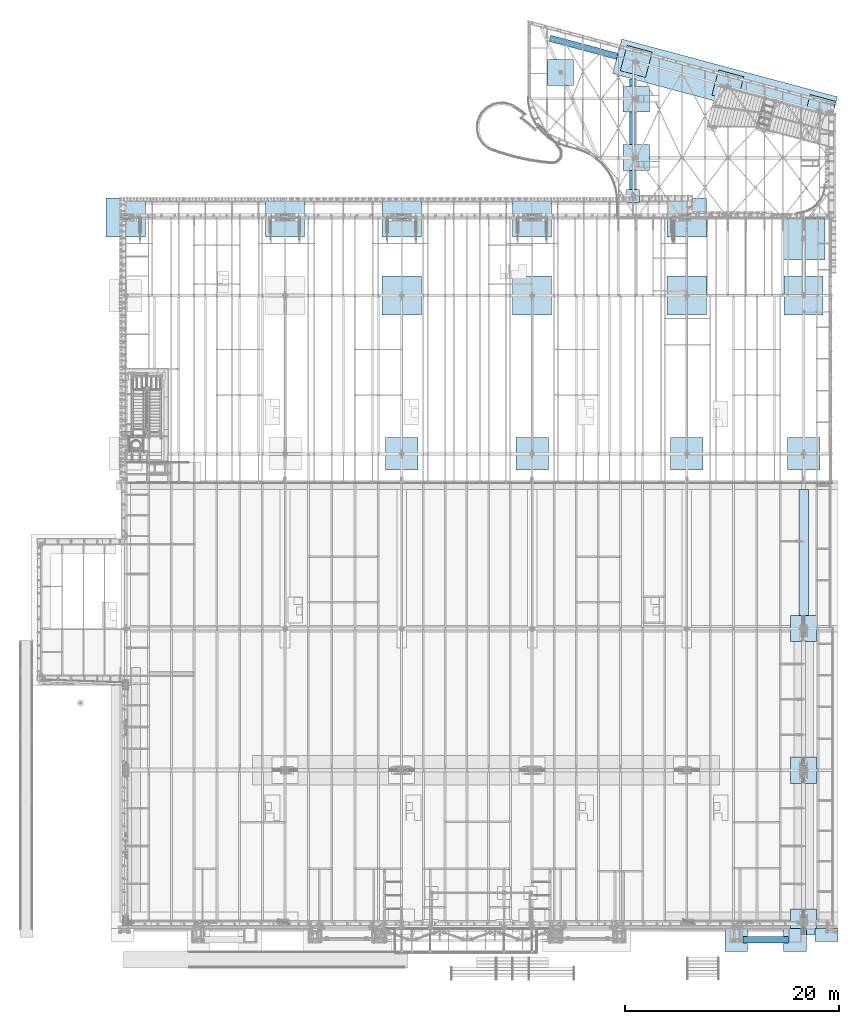
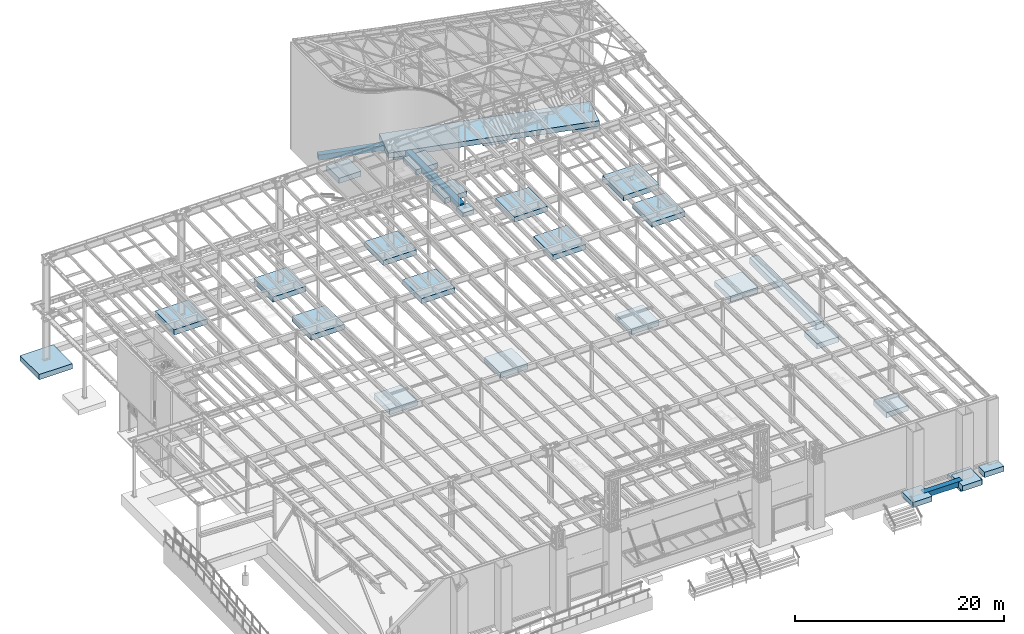
# One storey, part 870 of 1763: 32 footings, 32 elements without a shape of their own.
"""IFC2X3 building model written with IfcOpenShell, lengths in millimetres."""

import ifcopenshell
import ifcopenshell.guid

model = None  # the IFC model being written
_history = None  # IfcOwnerHistory: only IFC2X3 demands one
_inside = {}  # id of a spatial element -> (the spatial element, [elements in it])
_under = {}  # id of a project, library or spatial element -> (it, [spatial elements below it])
_declared = {}  # id of a project -> (the project, [libraries it declares])
_typed = {}  # id of a type object -> (the type object, [elements of that type])
_made_of = {}  # id of a material, layer set ... -> (it, [elements and type objects made of it])


def new_model(schema):
    """Start an empty IFC model of exactly this schema.

    Asked for "IFC4X3", IfcOpenShell would pick the latest addendum, in which some entities
    have other attributes; the version numbers below select the first issue.
    IFC2X3 requires an IfcOwnerHistory on every rooted entity: one is made here for all.
    """
    global model, _history
    if schema == "IFC4X3":
        model = ifcopenshell.file(schema_version=(4, 3, 0, 0))
    else:
        model = ifcopenshell.file(schema=schema)
    _inside.clear()
    _under.clear()
    _declared.clear()
    _typed.clear()
    _made_of.clear()
    _history = None
    if model.schema == "IFC2X3":
        org = make("IfcOrganization", Name="unknown")
        user = make(
            "IfcPersonAndOrganization",
            ThePerson=make("IfcPerson", FamilyName="unknown"),
            TheOrganization=org,
        )
        app = make(
            "IfcApplication",
            ApplicationDeveloper=org,
            Version="unknown",
            ApplicationFullName="unknown",
            ApplicationIdentifier="unknown",
        )
        _history = make(
            "IfcOwnerHistory",
            OwningUser=user,
            OwningApplication=app,
            ChangeAction="ADDED",
            CreationDate=0,
        )
    return model


def make(cls, **values):
    """One entity of the class cls with the attributes given. An attribute that is None is left unset."""
    return model.create_entity(
        cls, **{name: value for name, value in values.items() if value is not None}
    )


def rooted(cls, **values):
    """An entity with a GlobalId (a new one), such as an element, a storey or a relation."""
    return make(cls, GlobalId=ifcopenshell.guid.new(), OwnerHistory=_history, **values)


def si_unit(unit_type, name, prefix=None):
    """IfcSIUnit, for example si_unit("LENGTHUNIT", "METRE", prefix="MILLI")."""
    return make("IfcSIUnit", UnitType=unit_type, Prefix=prefix, Name=name)


def assignment(units):
    """IfcUnitAssignment: the units of a project."""
    return None if units is None else make("IfcUnitAssignment", Units=units)


def point(xyz):
    """IfcCartesianPoint."""
    return None if xyz is None else make("IfcCartesianPoint", Coordinates=xyz)


def direction(xyz):
    """IfcDirection."""
    return None if xyz is None else make("IfcDirection", DirectionRatios=xyz)


def frame(location, z_axis=None, x_axis=None):
    """IfcAxis2Placement3D, a coordinate frame: its origin and axes. An axis left out is left unset."""
    return make(
        "IfcAxis2Placement3D",
        Location=point(location),
        Axis=direction(z_axis),
        RefDirection=direction(x_axis),
    )


def origin_with_axes():
    """The frame at (0, 0, 0) with the z axis (0, 0, 1) and the x axis (1, 0, 0) written out."""
    return frame((0.0, 0.0, 0.0), z_axis=(0.0, 0.0, 1.0), x_axis=(1.0, 0.0, 0.0))


def place(relative_to, where):
    """IfcLocalPlacement: puts the frame where relative to a parent placement (None: the world)."""
    return make(
        "IfcLocalPlacement", PlacementRelTo=relative_to, RelativePlacement=where
    )


def context(
    kind, dimensions, precision=None, world=None, true_north=None, identifier=None
):
    """IfcGeometricRepresentationContext, for example the 3D "Model" context."""
    return make(
        "IfcGeometricRepresentationContext",
        ContextIdentifier=identifier,
        ContextType=kind,
        CoordinateSpaceDimension=dimensions,
        Precision=precision,
        WorldCoordinateSystem=world,
        TrueNorth=true_north,
    )


def subcontext(parent, identifier, kind, view, scale=None):
    """IfcGeometricRepresentationSubContext, for example "Body" below "Model"."""
    return make(
        "IfcGeometricRepresentationSubContext",
        ContextIdentifier=identifier,
        ContextType=kind,
        ParentContext=parent,
        TargetScale=scale,
        TargetView=view,
    )


def project(units=None, contexts=None):
    """IfcProject with its units and contexts."""
    return rooted(
        "IfcProject",
        Name="project",
        RepresentationContexts=contexts,
        UnitsInContext=assignment(units),
    )


def spatial(cls, under=None, at=None, **own):
    """A site, building, storey or space (cls), placed at a placement, below another one or the project."""
    s = rooted(cls, ObjectPlacement=at, **own)
    if under is not None:
        _under.setdefault(under.id(), (under, []))[1].append(s)
    return s


def faces_of(points, faces, orient=None, outer=None):
    """IfcFace entities. A face is a list of loops; a loop is a list of indices into points, from 0.

    orient and outer hold one flag for each loop. By default every Orientation is true, the
    first loop of a face is its IfcFaceOuterBound and the others are IfcFaceBound.
    """
    made = []
    for i, loops in enumerate(faces):
        bounds = []
        for j, loop in enumerate(loops):
            is_outer = j == 0 if outer is None else outer[i][j]
            bounds.append(
                make(
                    "IfcFaceOuterBound" if is_outer else "IfcFaceBound",
                    Bound=make("IfcPolyLoop", Polygon=[points[k] for k in loop]),
                    Orientation=True if orient is None else orient[i][j],
                )
            )
        made.append(make("IfcFace", Bounds=bounds))
    return made


def faceted_brep(points, faces, orient=None, outer=None, voids=None):
    """IfcFacetedBrep: a solid bounded by flat faces; with voids (closed shells), ...WithVoids."""
    shared = [point(p) for p in points]
    hull = make("IfcClosedShell", CfsFaces=faces_of(shared, faces, orient, outer))
    if voids is None:
        return make("IfcFacetedBrep", Outer=hull)
    return make(
        "IfcFacetedBrepWithVoids",
        Outer=hull,
        Voids=[
            make(cls, CfsFaces=faces_of(shared, fs, o, b)) for cls, fs, o, b in voids
        ],
    )


def shape(context_of_items, identifier, shape_type, items):
    """IfcShapeRepresentation: the items that make up one representation, for example the "Body"."""
    return make(
        "IfcShapeRepresentation",
        ContextOfItems=context_of_items,
        RepresentationIdentifier=identifier,
        RepresentationType=shape_type,
        Items=items,
    )


def material(Name=None, Category=None):
    """IfcMaterial."""
    return make("IfcMaterial", Name=Name, Category=Category)


def made_of(thing, what):
    """Note that an element or type object is made of a material, layer set ...; save() writes the relation."""
    if what is not None:
        _made_of.setdefault(what.id(), (what, []))[1].append(thing)
    return thing


def element(
    cls,
    number,
    at=None,
    inside=None,
    cuts=None,
    type_object=None,
    material=None,
    context=None,
    identifier="Body",
    shape_type=None,
    held_by="IfcProductDefinitionShape",
    body=None,
    shapes=None,
    **own,
):
    """One element of the class cls, such as IfcWall. Its Tag is "e" and its number.

    at: its placement. inside: the storey or other place that contains it. cuts: it is an
    opening in that element (IfcRelVoidsElement). A single representation is given by context,
    identifier, shape_type and body (its items); several are given by shapes. held_by: the class
    of the entity that holds the representations. save() writes the other relations.
    """
    e = rooted(cls, Tag="e%d" % number, ObjectPlacement=at, **own)
    if body is not None:
        shapes = [shape(context, identifier, shape_type, body)]
    if shapes is not None:
        e.Representation = make(held_by, Representations=shapes)
    if inside is not None:
        _inside.setdefault(inside.id(), (inside, []))[1].append(e)
    if cuts is not None:
        rooted(
            "IfcRelVoidsElement", RelatingBuildingElement=cuts, RelatedOpeningElement=e
        )
    if type_object is not None:
        _typed.setdefault(type_object.id(), (type_object, []))[1].append(e)
    return made_of(e, material)


def aggregate(whole, parts):
    """IfcRelAggregates: a whole, such as a stair, and the parts it consists of."""
    return rooted("IfcRelAggregates", RelatingObject=whole, RelatedObjects=parts)


def save(model, path):
    """Write the relations noted so far, then the file.

    IfcRelAggregates (storeys below a building ...), IfcRelContainedInSpatialStructure (elements
    in a storey), IfcRelDefinesByType, IfcRelAssociatesMaterial and IfcRelDeclares: one each for
    every whole, place, type object, material and project.
    """
    for whole, parts in _under.values():
        aggregate(whole, parts)
    for where, things in _inside.values():
        rooted(
            "IfcRelContainedInSpatialStructure",
            RelatedElements=things,
            RelatingStructure=where,
        )
    for kind, things in _typed.values():
        rooted("IfcRelDefinesByType", RelatedObjects=things, RelatingType=kind)
    for what, things in _made_of.values():
        rooted("IfcRelAssociatesMaterial", RelatedObjects=things, RelatingMaterial=what)
    for by, libraries in _declared.values():
        rooted("IfcRelDeclares", RelatingContext=by, RelatedDefinitions=libraries)
    model.write(path)


model = new_model("IFC2X3")

# Units and contexts
model_context = context("Model", 3, precision=1e-05, world=origin_with_axes())
body_context = subcontext(model_context, "Body", "Model", "MODEL_VIEW")
ifc_project = project(units=[si_unit("LENGTHUNIT", "METRE", prefix="MILLI"), si_unit("AREAUNIT", "SQUARE_METRE"), si_unit("VOLUMEUNIT", "CUBIC_METRE"), si_unit("MASSUNIT", "GRAM", prefix="KILO"), si_unit("TIMEUNIT", "SECOND"), si_unit("PLANEANGLEUNIT", "RADIAN"), si_unit("SOLIDANGLEUNIT", "STERADIAN"), si_unit("THERMODYNAMICTEMPERATUREUNIT", "DEGREE_CELSIUS"), si_unit("LUMINOUSINTENSITYUNIT", "LUMEN")], contexts=[model_context])

# Site, building, storey
site_placement = place(None, origin_with_axes())
site = spatial("IfcSite", under=ifc_project, at=site_placement, CompositionType="ELEMENT")
building_placement = place(site_placement, origin_with_axes())
building = spatial("IfcBuilding", under=site, at=building_placement, Name="Undefined", CompositionType="ELEMENT")
storey_placement = place(building_placement, origin_with_axes())
storey = spatial("IfcBuildingStorey", under=building, at=storey_placement, Name="Undefined", CompositionType="ELEMENT", Elevation=0.0)

# Assembly, footing
assembly_1_placement = place(storey_placement, origin_with_axes())
assembly_1 = element("IfcElementAssembly", 1, at=assembly_1_placement, inside=storey, Name="STRIP FOOTING", AssemblyPlace="NOTDEFINED", PredefinedType="REINFORCEMENT_UNIT")
ifc_material = material(Name="CONCRETE/3000")
footing_1_placement = place(assembly_1_placement, frame((-24027.8372736984, 13995.3994140625, 4641.85), z_axis=(0.0, 0.0, 1.0), x_axis=(0.0, 1.0, 0.0)))
footing_1 = element("IfcFooting", 2, at=footing_1_placement, material=ifc_material, Name="STRIP FOOTING", PredefinedType="NOTDEFINED", context=body_context, shape_type="Brep", body=[
    faceted_brep([(0.0, 457.200000000001, -387.35), (0.0, 457.200000000001, 387.35), (12674.6005859375, 457.200000000001, 387.35), (12674.6005859375, 457.200000000001, -387.35), (0.0, -457.200000000001, 387.35), (12674.6005859375, -457.200000000001, 387.35), (0.0, -457.200000000001, -387.35), (12674.6005859375, -457.200000000001, -387.35)], [[[0, 1, 2, 3]], [[1, 4, 5, 2]], [[4, 6, 7, 5]], [[6, 0, 3, 7]], [[5, 7, 3, 2]], [[6, 4, 1, 0]]]),
])
aggregate(assembly_1, [footing_1])

assembly_2_placement = place(storey_placement, origin_with_axes())
assembly_2 = element("IfcElementAssembly", 3, at=assembly_2_placement, inside=storey, Name="PAD FOOTING", AssemblyPlace="NOTDEFINED", PredefinedType="REINFORCEMENT_UNIT")
footing_2_placement = place(assembly_2_placement, frame((-24027.8372736984, -13716.0000000001, 3200.4), z_axis=(1.0, 0.0, 0.0), x_axis=(0.0, 0.0, 1.0)))
footing_2 = element("IfcFooting", 4, at=footing_2_placement, material=ifc_material, Name="PAD FOOTING", PredefinedType="NOTDEFINED", context=body_context, shape_type="Brep", body=[
    faceted_brep([(0.0, 1219.2, -1219.2), (0.0, 1219.2, 1219.2), (609.599999999999, 1219.2, 1219.2), (609.599999999999, 1219.2, -1219.2), (0.0, -1219.2, 1219.2), (609.599999999999, -1219.2, 1219.2), (0.0, -1219.2, -1219.2), (609.599999999999, -1219.2, -1219.2)], [[[0, 1, 2, 3]], [[1, 4, 5, 2]], [[4, 6, 7, 5]], [[6, 0, 3, 7]], [[5, 7, 3, 2]], [[6, 4, 1, 0]]]),
])
aggregate(assembly_2, [footing_2])

assembly_3_placement = place(storey_placement, origin_with_axes())
assembly_3 = element("IfcElementAssembly", 5, at=assembly_3_placement, inside=storey, Name="PAD FOOTING", AssemblyPlace="NOTDEFINED", PredefinedType="REINFORCEMENT_UNIT")
footing_3_placement = place(assembly_3_placement, frame((-24027.8372736984, 13690.6, 3200.4), z_axis=(1.0, 0.0, 0.0), x_axis=(0.0, 0.0, 1.0)))
footing_3 = element("IfcFooting", 6, at=footing_3_placement, material=ifc_material, Name="PAD FOOTING", PredefinedType="NOTDEFINED", context=body_context, shape_type="Brep", body=[
    faceted_brep([(0.0, 1219.2, -1219.2), (0.0, 1219.2, 1219.2), (609.599999999999, 1219.2, 1219.2), (609.599999999999, 1219.2, -1219.2), (0.0, -1219.2, 1219.2), (609.599999999999, -1219.2, 1219.2), (0.0, -1219.2, -1219.2), (609.599999999999, -1219.2, -1219.2)], [[[0, 1, 2, 3]], [[1, 4, 5, 2]], [[4, 6, 7, 5]], [[6, 0, 3, 7]], [[5, 7, 3, 2]], [[6, 4, 1, 0]]]),
])
aggregate(assembly_3, [footing_3])

assembly_4_placement = place(storey_placement, origin_with_axes())
assembly_4 = element("IfcElementAssembly", 7, at=assembly_4_placement, inside=storey, Name="PAD FOOTING", AssemblyPlace="NOTDEFINED", PredefinedType="REINFORCEMENT_UNIT")
footing_4_placement = place(assembly_4_placement, frame((-24027.8372736984, 457.199999999995, 3200.4), z_axis=(1.0, 0.0, 0.0), x_axis=(0.0, 0.0, 1.0)))
footing_4 = element("IfcFooting", 8, at=footing_4_placement, material=ifc_material, Name="PAD FOOTING", PredefinedType="NOTDEFINED", context=body_context, shape_type="Brep", body=[
    faceted_brep([(0.0, 1219.2, -1219.2), (0.0, 1219.2, 1219.2), (609.599999999999, 1219.2, 1219.2), (609.599999999999, 1219.2, -1219.2), (0.0, -1219.2, 1219.2), (609.599999999999, -1219.2, 1219.2), (0.0, -1219.2, -1219.2), (609.599999999999, -1219.2, -1219.2)], [[[0, 1, 2, 3]], [[1, 4, 5, 2]], [[4, 6, 7, 5]], [[6, 0, 3, 7]], [[5, 7, 3, 2]], [[6, 4, 1, 0]]]),
])
aggregate(assembly_4, [footing_4])

assembly_5_placement = place(storey_placement, origin_with_axes())
assembly_5 = element("IfcElementAssembly", 9, at=assembly_5_placement, inside=storey, Name="STRIP FOOTING", AssemblyPlace="NOTDEFINED", PredefinedType="REINFORCEMENT_UNIT")
footing_5_placement = place(assembly_5_placement, frame((-29717.4383006056, -15367.0002424476, 4724.4), z_axis=(0.0, 0.0, 1.0), x_axis=(1.0, 0.0, 0.0)))
footing_5 = element("IfcFooting", 10, at=footing_5_placement, material=ifc_material, Name="STRIP FOOTING", PredefinedType="NOTDEFINED", context=body_context, shape_type="Brep", body=[
    faceted_brep([(0.0, 304.799999999999, -304.8), (0.0, 304.799999999999, 304.8), (4267.19970703125, 304.799999999999, 304.8), (4267.19970703125, 304.799999999999, -304.8), (0.0, -304.799999999999, 304.8), (4267.19970703125, -304.799999999999, 304.8), (0.0, -304.799999999999, -304.8), (4267.19970703125, -304.799999999999, -304.8)], [[[0, 1, 2, 3]], [[1, 4, 5, 2]], [[4, 6, 7, 5]], [[6, 0, 3, 7]], [[5, 7, 3, 2]], [[6, 4, 1, 0]]]),
])
aggregate(assembly_5, [footing_5])

assembly_6_placement = place(storey_placement, origin_with_axes())
assembly_6 = element("IfcElementAssembly", 11, at=assembly_6_placement, inside=storey, Name="PAD FOOTING", AssemblyPlace="NOTDEFINED", PredefinedType="REINFORCEMENT_UNIT")
footing_6_placement = place(assembly_6_placement, frame((-21881.5372736984, -14960.6000410316, 4419.6), z_axis=(1.0, 0.0, 0.0), x_axis=(0.0, 0.0, 1.0)))
footing_6 = element("IfcFooting", 12, at=footing_6_placement, material=ifc_material, Name="PAD FOOTING", PredefinedType="NOTDEFINED", context=body_context, shape_type="Brep", body=[
    faceted_brep([(0.0, 609.6, -1066.8), (0.0, 609.6, 1066.8), (609.599999999999, 609.6, 1066.8), (609.599999999999, 609.6, -1066.8), (0.0, -609.6, 1066.8), (609.599999999999, -609.6, 1066.8), (0.0, -609.6, -1066.8), (609.599999999999, -609.6, -1066.8)], [[[0, 1, 2, 3]], [[1, 4, 5, 2]], [[4, 6, 7, 5]], [[6, 0, 3, 7]], [[5, 7, 3, 2]], [[6, 4, 1, 0]]]),
])
aggregate(assembly_6, [footing_6])

assembly_7_placement = place(storey_placement, origin_with_axes())
assembly_7 = element("IfcElementAssembly", 13, at=assembly_7_placement, inside=storey, Name="PAD FOOTING", AssemblyPlace="NOTDEFINED", PredefinedType="REINFORCEMENT_UNIT")
footing_7_placement = place(assembly_7_placement, frame((-30327.0382761915, -15417.8001753089, 4419.6), z_axis=(1.0, 0.0, 0.0), x_axis=(0.0, 0.0, 1.0)))
footing_7 = element("IfcFooting", 14, at=footing_7_placement, material=ifc_material, Name="PAD FOOTING", PredefinedType="NOTDEFINED", context=body_context, shape_type="Brep", body=[
    faceted_brep([(0.0, 1066.8, -1066.8), (0.0, 1066.8, 1066.8), (609.599999999999, 1066.8, 1066.8), (609.599999999999, 1066.8, -1066.8), (0.0, -1066.8, 1066.8), (609.599999999999, -1066.8, 1066.8), (0.0, -1066.8, -1066.8), (609.599999999999, -1066.8, -1066.8)], [[[0, 1, 2, 3]], [[1, 4, 5, 2]], [[4, 6, 7, 5]], [[6, 0, 3, 7]], [[5, 7, 3, 2]], [[6, 4, 1, 0]]]),
])
aggregate(assembly_7, [footing_7])

assembly_8_placement = place(storey_placement, origin_with_axes())
assembly_8 = element("IfcElementAssembly", 15, at=assembly_8_placement, inside=storey, Name="PAD FOOTING", AssemblyPlace="NOTDEFINED", PredefinedType="REINFORCEMENT_UNIT")
footing_8_placement = place(assembly_8_placement, frame((-24840.6383738478, -15417.8000532386, 4419.6), z_axis=(1.0, 0.0, 0.0), x_axis=(0.0, 0.0, 1.0)))
footing_8 = element("IfcFooting", 16, at=footing_8_placement, material=ifc_material, Name="PAD FOOTING", PredefinedType="NOTDEFINED", context=body_context, shape_type="Brep", body=[
    faceted_brep([(0.0, 1066.8, -1066.8), (0.0, 1066.8, 1066.8), (609.599999999999, 1066.8, 1066.8), (609.599999999999, 1066.8, -1066.8), (0.0, -1066.8, 1066.8), (609.599999999999, -1066.8, 1066.8), (0.0, -1066.8, -1066.8), (609.599999999999, -1066.8, -1066.8)], [[[0, 1, 2, 3]], [[1, 4, 5, 2]], [[4, 6, 7, 5]], [[6, 0, 3, 7]], [[5, 7, 3, 2]], [[6, 4, 1, 0]]]),
])
aggregate(assembly_8, [footing_8])

assembly_9_placement = place(storey_placement, origin_with_axes())
assembly_9 = element("IfcElementAssembly", 17, at=assembly_9_placement, inside=storey, Name="PAD FOOTING", AssemblyPlace="NOTDEFINED", PredefinedType="REINFORCEMENT_UNIT")
footing_9_placement = place(assembly_9_placement, frame((-22552.6896174484, 62105.6323986002, -1524.0), z_axis=(0.965913267114843, -0.258865912030785, 0.0), x_axis=(0.0, 0.0, 1.0)))
footing_9 = element("IfcFooting", 18, at=footing_9_placement, material=ifc_material, Name="PAD FOOTING", PredefinedType="NOTDEFINED", context=body_context, shape_type="Brep", body=[
    faceted_brep([(0.0, 1219.2, -1219.2), (0.0, 1219.2, 1219.2), (609.599999999999, 1219.2, 1219.2), (609.599999999999, 1219.2, -1219.2), (0.0, -1219.2, 1219.2), (609.599999999999, -1219.2, 1219.2), (0.0, -1219.2, -1219.2), (609.599999999999, -1219.2, -1219.2)], [[[0, 1, 2, 3]], [[1, 4, 5, 2]], [[4, 6, 7, 5]], [[6, 0, 3, 7]], [[5, 7, 3, 2]], [[6, 4, 1, 0]]]),
])
aggregate(assembly_9, [footing_9])

assembly_10_placement = place(storey_placement, origin_with_axes())
assembly_10 = element("IfcElementAssembly", 19, at=assembly_10_placement, inside=storey, Name="PAD FOOTING", AssemblyPlace="NOTDEFINED", PredefinedType="REINFORCEMENT_UNIT")
footing_10_placement = place(assembly_10_placement, frame((-31112.4896174484, 64399.6690468592, -1524.0), z_axis=(0.965913267114843, -0.258865912030785, 0.0), x_axis=(0.0, 0.0, 1.0)))
footing_10 = element("IfcFooting", 20, at=footing_10_placement, material=ifc_material, Name="PAD FOOTING", PredefinedType="NOTDEFINED", context=body_context, shape_type="Brep", body=[
    faceted_brep([(0.0, 1219.2, -1219.2), (0.0, 1219.2, 1219.2), (609.599999999999, 1219.2, 1219.2), (609.599999999999, 1219.2, -1219.2), (0.0, -1219.2, 1219.2), (609.599999999999, -1219.2, 1219.2), (0.0, -1219.2, -1219.2), (609.599999999999, -1219.2, -1219.2)], [[[0, 1, 2, 3]], [[1, 4, 5, 2]], [[4, 6, 7, 5]], [[6, 0, 3, 7]], [[5, 7, 3, 2]], [[6, 4, 1, 0]]]),
])
aggregate(assembly_10, [footing_10])

assembly_11_placement = place(storey_placement, origin_with_axes())
assembly_11 = element("IfcElementAssembly", 21, at=assembly_11_placement, inside=storey, Name="PAD FOOTING", AssemblyPlace="NOTDEFINED", PredefinedType="REINFORCEMENT_UNIT")
footing_11_placement = place(assembly_11_placement, frame((-39672.2896174443, 66693.7056949813, -1524.0), z_axis=(0.965913267114843, -0.258865912030785, 0.0), x_axis=(0.0, 0.0, 1.0)))
footing_11 = element("IfcFooting", 22, at=footing_11_placement, material=ifc_material, Name="PAD FOOTING", PredefinedType="NOTDEFINED", context=body_context, shape_type="Brep", body=[
    faceted_brep([(0.0, 1219.2, -1219.2), (0.0, 1219.2, 1219.2), (609.599999999999, 1219.2, 1219.2), (609.599999999999, 1219.2, -1219.2), (0.0, -1219.2, 1219.2), (609.599999999999, -1219.2, 1219.2), (0.0, -1219.2, -1219.2), (609.599999999999, -1219.2, -1219.2)], [[[0, 1, 2, 3]], [[1, 4, 5, 2]], [[4, 6, 7, 5]], [[6, 0, 3, 7]], [[5, 7, 3, 2]], [[6, 4, 1, 0]]]),
])
aggregate(assembly_11, [footing_11])

assembly_12_placement = place(storey_placement, origin_with_axes())
assembly_12 = element("IfcElementAssembly", 23, at=assembly_12_placement, inside=storey, Name="STRIP FOOTING", AssemblyPlace="NOTDEFINED", PredefinedType="REINFORCEMENT_UNIT")
footing_12_placement = place(assembly_12_placement, frame((-39977.0896174484, 54730.6500000006, -609.6), z_axis=(0.0, 0.0, 1.0), x_axis=(0.0, 1.0, 0.0)))
footing_12 = element("IfcFooting", 24, at=footing_12_placement, material=ifc_material, Name="STRIP FOOTING", PredefinedType="NOTDEFINED", context=body_context, shape_type="Brep", body=[
    faceted_brep([(0.0, 304.799999999999, -304.8), (0.0, 304.799999999999, 304.8), (10309.1829050839, 304.800000000003, 304.8), (10309.1829050839, 304.800000000003, -304.8), (0.0, -304.799999999999, 304.8), (10309.1829050839, -304.800000000003, 304.8), (0.0, -304.799999999999, -304.8), (10309.1829050839, -304.800000000003, -304.8)], [[[0, 1, 2, 3]], [[1, 4, 5, 2]], [[4, 6, 7, 5]], [[6, 0, 3, 7]], [[5, 7, 3, 2]], [[6, 4, 1, 0]]]),
])
aggregate(assembly_12, [footing_12])

assembly_13_placement = place(storey_placement, origin_with_axes())
assembly_13 = element("IfcElementAssembly", 25, at=assembly_13_placement, inside=storey, Name="PAD FOOTING", AssemblyPlace="NOTDEFINED", PredefinedType="REINFORCEMENT_UNIT")
footing_13_placement = place(assembly_13_placement, frame((-39977.0896174484, 54121.0500000006, -914.4), z_axis=(1.0, 0.0, 0.0), x_axis=(0.0, 0.0, 1.0)))
footing_13 = element("IfcFooting", 26, at=footing_13_placement, material=ifc_material, Name="PAD FOOTING", PredefinedType="NOTDEFINED", context=body_context, shape_type="Brep", body=[
    faceted_brep([(0.0, 609.599999999999, -609.599999999999), (0.0, 609.599999999999, 609.599999999999), (457.2, 609.599999999999, 609.599999999999), (457.2, 609.599999999999, -609.599999999999), (0.0, -609.599999999999, 609.599999999999), (457.2, -609.599999999999, 609.599999999999), (0.0, -609.599999999999, -609.599999999999), (457.2, -609.599999999999, -609.599999999999)], [[[0, 1, 2, 3]], [[1, 4, 5, 2]], [[4, 6, 7, 5]], [[6, 0, 3, 7]], [[5, 7, 3, 2]], [[6, 4, 1, 0]]]),
])
aggregate(assembly_13, [footing_13])

assembly_14_placement = place(storey_placement, origin_with_axes())
assembly_14 = element("IfcElementAssembly", 27, at=assembly_14_placement, inside=storey, Name="STRIP FOOTING", AssemblyPlace="NOTDEFINED", PredefinedType="REINFORCEMENT_UNIT")
footing_14_placement = place(assembly_14_placement, frame((-41460.2192227076, 67172.8729699345, -609.6), z_axis=(0.0, 0.0, 1.0), x_axis=(0.965913267114843, -0.258865912030785, 0.0)))
footing_14 = element("IfcFooting", 28, at=footing_14_placement, material=ifc_material, Name="STRIP FOOTING", PredefinedType="NOTDEFINED", context=body_context, shape_type="Brep", body=[
    faceted_brep([(2.10275175049901e-09, 1676.39999998813, -304.8), (2.10275175049901e-09, 1676.39999998813, 304.8), (20869.5679480647, 1676.39999985453, 304.8), (20869.5679480647, 1676.39999985453, -304.8), (-2.11730366572738e-09, -1676.39999998813, 304.8), (20869.5679480605, -1676.40000012173, 304.8), (-2.11730366572738e-09, -1676.39999998813, -304.8), (20869.5679480605, -1676.40000012173, -304.8)], [[[0, 1, 2, 3]], [[1, 4, 5, 2]], [[4, 6, 7, 5]], [[6, 0, 3, 7]], [[5, 7, 3, 2]], [[6, 4, 1, 0]]]),
])
aggregate(assembly_14, [footing_14])

assembly_15_placement = place(storey_placement, origin_with_axes())
assembly_15 = element("IfcElementAssembly", 29, at=assembly_15_placement, inside=storey, Name="STRIP FOOTING", AssemblyPlace="NOTDEFINED", PredefinedType="REINFORCEMENT_UNIT")
footing_15_placement = place(assembly_15_placement, frame((-47749.4896174484, 68858.4049655823, -609.6), z_axis=(0.0, 0.0, 1.0), x_axis=(0.965913267114843, -0.258865912030785, 0.0)))
footing_15 = element("IfcFooting", 30, at=footing_15_placement, material=ifc_material, Name="STRIP FOOTING", PredefinedType="NOTDEFINED", context=body_context, shape_type="Brep", body=[
    faceted_brep([(0.0, 304.799999999999, -304.8), (0.0, 304.799999999999, 304.8), (6511.21649207542, 304.799999956165, 304.8), (6511.21649207542, 304.799999956165, -304.8), (0.0, -304.799999999999, 304.8), (6511.21649207466, -304.800000039526, 304.8), (0.0, -304.799999999999, -304.8), (6511.21649207466, -304.800000039526, -304.8)], [[[0, 1, 2, 3]], [[1, 4, 5, 2]], [[4, 6, 7, 5]], [[6, 0, 3, 7]], [[5, 7, 3, 2]], [[6, 4, 1, 0]]]),
])
aggregate(assembly_15, [footing_15])

assembly_16_placement = place(storey_placement, origin_with_axes())
assembly_16 = element("IfcElementAssembly", 31, at=assembly_16_placement, inside=storey, Name="PAD FOOTING", AssemblyPlace="NOTDEFINED", PredefinedType="REINFORCEMENT_UNIT")
footing_16_placement = place(assembly_16_placement, frame((-46733.4896174484, 65678.0500000006, -1066.8), z_axis=(1.0, 0.0, 0.0), x_axis=(0.0, 0.0, 1.0)))
footing_16 = element("IfcFooting", 32, at=footing_16_placement, material=ifc_material, Name="PAD FOOTING", PredefinedType="NOTDEFINED", context=body_context, shape_type="Brep", body=[
    faceted_brep([(0.0, 1219.2, -1219.2), (0.0, 1219.2, 1219.2), (609.599999999999, 1219.2, 1219.2), (609.599999999999, 1219.2, -1219.2), (0.0, -1219.2, 1219.2), (609.599999999999, -1219.2, 1219.2), (0.0, -1219.2, -1219.2), (609.599999999999, -1219.2, -1219.2)], [[[0, 1, 2, 3]], [[1, 4, 5, 2]], [[4, 6, 7, 5]], [[6, 0, 3, 7]], [[5, 7, 3, 2]], [[6, 4, 1, 0]]]),
])
aggregate(assembly_16, [footing_16])

assembly_17_placement = place(storey_placement, origin_with_axes())
assembly_17 = element("IfcElementAssembly", 33, at=assembly_17_placement, inside=storey, Name="PAD FOOTING", AssemblyPlace="NOTDEFINED", PredefinedType="REINFORCEMENT_UNIT")
footing_17_placement = place(assembly_17_placement, frame((-39672.2896174484, 57702.4500000006, -1066.8), z_axis=(1.0, 0.0, 0.0), x_axis=(0.0, 0.0, 1.0)))
footing_17 = element("IfcFooting", 34, at=footing_17_placement, material=ifc_material, Name="PAD FOOTING", PredefinedType="NOTDEFINED", context=body_context, shape_type="Brep", body=[
    faceted_brep([(0.0, 1219.2, -1219.2), (0.0, 1219.2, 1219.2), (609.599999999999, 1219.2, 1219.2), (609.599999999999, 1219.2, -1219.2), (0.0, -1219.2, 1219.2), (609.599999999999, -1219.2, 1219.2), (0.0, -1219.2, -1219.2), (609.599999999999, -1219.2, -1219.2)], [[[0, 1, 2, 3]], [[1, 4, 5, 2]], [[4, 6, 7, 5]], [[6, 0, 3, 7]], [[5, 7, 3, 2]], [[6, 4, 1, 0]]]),
])
aggregate(assembly_17, [footing_17])

assembly_18_placement = place(storey_placement, origin_with_axes())
assembly_18 = element("IfcElementAssembly", 35, at=assembly_18_placement, inside=storey, Name="PAD FOOTING", AssemblyPlace="NOTDEFINED", PredefinedType="REINFORCEMENT_UNIT")
footing_18_placement = place(assembly_18_placement, frame((-39672.2896174484, 63201.5500000006, -1066.8), z_axis=(1.0, 0.0, 0.0), x_axis=(0.0, 0.0, 1.0)))
footing_18 = element("IfcFooting", 36, at=footing_18_placement, material=ifc_material, Name="PAD FOOTING", PredefinedType="NOTDEFINED", context=body_context, shape_type="Brep", body=[
    faceted_brep([(0.0, 1219.2, -1219.2), (0.0, 1219.2, 1219.2), (609.599999999999, 1219.2, 1219.2), (609.599999999999, 1219.2, -1219.2), (0.0, -1219.2, 1219.2), (609.599999999999, -1219.2, 1219.2), (0.0, -1219.2, -1219.2), (609.599999999999, -1219.2, -1219.2)], [[[0, 1, 2, 3]], [[1, 4, 5, 2]], [[4, 6, 7, 5]], [[6, 0, 3, 7]], [[5, 7, 3, 2]], [[6, 4, 1, 0]]]),
])
aggregate(assembly_18, [footing_18])

assembly_19_placement = place(storey_placement, origin_with_axes())
assembly_19 = element("IfcElementAssembly", 37, at=assembly_19_placement, inside=storey, Name="PAD FOOTING", AssemblyPlace="NOTDEFINED", PredefinedType="REINFORCEMENT_UNIT")
footing_19_placement = place(assembly_19_placement, frame((-87375.4372736983, 52120.8, -914.4), z_axis=(1.0, 0.0, 0.0), x_axis=(0.0, 0.0, 1.0)))
footing_19 = element("IfcFooting", 38, at=footing_19_placement, material=ifc_material, Name="PAD FOOTING", PredefinedType="NOTDEFINED", context=body_context, shape_type="Brep", body=[
    faceted_brep([(0.0, 1828.8, -1828.8), (0.0, 1828.8, 1828.8), (609.6, 1828.8, 1828.8), (609.6, 1828.8, -1828.8), (0.0, -1828.8, 1828.8), (609.6, -1828.8, 1828.8), (0.0, -1828.8, -1828.8), (609.6, -1828.8, -1828.8)], [[[0, 1, 2, 3]], [[1, 4, 5, 2]], [[4, 6, 7, 5]], [[6, 0, 3, 7]], [[5, 7, 3, 2]], [[6, 4, 1, 0]]]),
])
aggregate(assembly_19, [footing_19])

assembly_20_placement = place(storey_placement, origin_with_axes())
assembly_20 = element("IfcElementAssembly", 39, at=assembly_20_placement, inside=storey, Name="PAD FOOTING", AssemblyPlace="NOTDEFINED", PredefinedType="REINFORCEMENT_UNIT")
footing_20_placement = place(assembly_20_placement, frame((-72491.0372736984, 52120.8, -914.4), z_axis=(1.0, 0.0, 0.0), x_axis=(0.0, 0.0, 1.0)))
footing_20 = element("IfcFooting", 40, at=footing_20_placement, material=ifc_material, Name="PAD FOOTING", PredefinedType="NOTDEFINED", context=body_context, shape_type="Brep", body=[
    faceted_brep([(0.0, 1828.8, -1828.8), (0.0, 1828.8, 1828.8), (609.6, 1828.8, 1828.8), (609.6, 1828.8, -1828.8), (0.0, -1828.8, 1828.8), (609.6, -1828.8, 1828.8), (0.0, -1828.8, -1828.8), (609.6, -1828.8, -1828.8)], [[[0, 1, 2, 3]], [[1, 4, 5, 2]], [[4, 6, 7, 5]], [[6, 0, 3, 7]], [[5, 7, 3, 2]], [[6, 4, 1, 0]]]),
])
aggregate(assembly_20, [footing_20])

assembly_21_placement = place(storey_placement, origin_with_axes())
assembly_21 = element("IfcElementAssembly", 41, at=assembly_21_placement, inside=storey, Name="PAD FOOTING", AssemblyPlace="NOTDEFINED", PredefinedType="REINFORCEMENT_UNIT")
footing_21_placement = place(assembly_21_placement, frame((-61594.4372736983, 52120.8, -914.4), z_axis=(1.0, 0.0, 0.0), x_axis=(0.0, 0.0, 1.0)))
footing_21 = element("IfcFooting", 42, at=footing_21_placement, material=ifc_material, Name="PAD FOOTING", PredefinedType="NOTDEFINED", context=body_context, shape_type="Brep", body=[
    faceted_brep([(0.0, 1828.8, -1828.8), (0.0, 1828.8, 1828.8), (609.6, 1828.8, 1828.8), (609.6, 1828.8, -1828.8), (0.0, -1828.8, 1828.8), (609.6, -1828.8, 1828.8), (0.0, -1828.8, -1828.8), (609.6, -1828.8, -1828.8)], [[[0, 1, 2, 3]], [[1, 4, 5, 2]], [[4, 6, 7, 5]], [[6, 0, 3, 7]], [[5, 7, 3, 2]], [[6, 4, 1, 0]]]),
])
aggregate(assembly_21, [footing_21])

assembly_22_placement = place(storey_placement, origin_with_axes())
assembly_22 = element("IfcElementAssembly", 43, at=assembly_22_placement, inside=storey, Name="PAD FOOTING", AssemblyPlace="NOTDEFINED", PredefinedType="REINFORCEMENT_UNIT")
footing_22_placement = place(assembly_22_placement, frame((-49402.4372736983, 52120.8, -914.4), z_axis=(1.0, 0.0, 0.0), x_axis=(0.0, 0.0, 1.0)))
footing_22 = element("IfcFooting", 44, at=footing_22_placement, material=ifc_material, Name="PAD FOOTING", PredefinedType="NOTDEFINED", context=body_context, shape_type="Brep", body=[
    faceted_brep([(0.0, 1828.8, -1828.8), (0.0, 1828.8, 1828.8), (609.6, 1828.8, 1828.8), (609.6, 1828.8, -1828.8), (0.0, -1828.8, 1828.8), (609.6, -1828.8, 1828.8), (0.0, -1828.8, -1828.8), (609.6, -1828.8, -1828.8)], [[[0, 1, 2, 3]], [[1, 4, 5, 2]], [[4, 6, 7, 5]], [[6, 0, 3, 7]], [[5, 7, 3, 2]], [[6, 4, 1, 0]]]),
])
aggregate(assembly_22, [footing_22])

assembly_23_placement = place(storey_placement, origin_with_axes())
assembly_23 = element("IfcElementAssembly", 45, at=assembly_23_placement, inside=storey, Name="PAD FOOTING", AssemblyPlace="NOTDEFINED", PredefinedType="REINFORCEMENT_UNIT")
footing_23_placement = place(assembly_23_placement, frame((-34949.8372736984, 52120.8, -914.4), z_axis=(1.0, 0.0, 0.0), x_axis=(0.0, 0.0, 1.0)))
footing_23 = element("IfcFooting", 46, at=footing_23_placement, material=ifc_material, Name="PAD FOOTING", PredefinedType="NOTDEFINED", context=body_context, shape_type="Brep", body=[
    faceted_brep([(0.0, 1828.8, -1828.8), (0.0, 1828.8, 1828.8), (609.6, 1828.8, 1828.8), (609.6, 1828.8, -1828.8), (0.0, -1828.8, 1828.8), (609.6, -1828.8, 1828.8), (0.0, -1828.8, -1828.8), (609.6, -1828.8, -1828.8)], [[[0, 1, 2, 3]], [[1, 4, 5, 2]], [[4, 6, 7, 5]], [[6, 0, 3, 7]], [[5, 7, 3, 2]], [[6, 4, 1, 0]]]),
])
aggregate(assembly_23, [footing_23])

assembly_24_placement = place(storey_placement, origin_with_axes())
assembly_24 = element("IfcElementAssembly", 47, at=assembly_24_placement, inside=storey, Name="PAD FOOTING", AssemblyPlace="NOTDEFINED", PredefinedType="REINFORCEMENT_UNIT")
footing_24_placement = place(assembly_24_placement, frame((-24027.8372736984, 50139.6, -914.4), z_axis=(1.0, 0.0, 0.0), x_axis=(0.0, 0.0, 1.0)))
footing_24 = element("IfcFooting", 48, at=footing_24_placement, material=ifc_material, Name="PAD FOOTING", PredefinedType="NOTDEFINED", context=body_context, shape_type="Brep", body=[
    faceted_brep([(0.0, 1981.2, -1981.2), (0.0, 1981.2, 1981.2), (609.6, 1981.2, 1981.2), (609.6, 1981.2, -1981.2), (0.0, -1981.2, 1981.2), (609.6, -1981.2, 1981.2), (0.0, -1981.2, -1981.2), (609.6, -1981.2, -1981.2)], [[[0, 1, 2, 3]], [[1, 4, 5, 2]], [[4, 6, 7, 5]], [[6, 0, 3, 7]], [[5, 7, 3, 2]], [[6, 4, 1, 0]]]),
])
aggregate(assembly_24, [footing_24])

assembly_25_placement = place(storey_placement, origin_with_axes())
assembly_25 = element("IfcElementAssembly", 49, at=assembly_25_placement, inside=storey, Name="PAD FOOTING", AssemblyPlace="NOTDEFINED", PredefinedType="REINFORCEMENT_UNIT")
footing_25_placement = place(assembly_25_placement, frame((-24027.8372736984, 30022.8, -914.4), z_axis=(1.0, 0.0, 0.0), x_axis=(0.0, 0.0, 1.0)))
footing_25 = element("IfcFooting", 50, at=footing_25_placement, material=ifc_material, Name="PAD FOOTING", PredefinedType="NOTDEFINED", context=body_context, shape_type="Brep", body=[
    faceted_brep([(0.0, 1524.0, -1524.0), (0.0, 1524.0, 1524.0), (609.6, 1524.0, 1524.0), (609.6, 1524.0, -1524.0), (0.0, -1524.0, 1524.0), (609.6, -1524.0, 1524.0), (0.0, -1524.0, -1524.0), (609.6, -1524.0, -1524.0)], [[[0, 1, 2, 3]], [[1, 4, 5, 2]], [[4, 6, 7, 5]], [[6, 0, 3, 7]], [[5, 7, 3, 2]], [[6, 4, 1, 0]]]),
])
aggregate(assembly_25, [footing_25])

assembly_26_placement = place(storey_placement, origin_with_axes())
assembly_26 = element("IfcElementAssembly", 51, at=assembly_26_placement, inside=storey, Name="PAD FOOTING", AssemblyPlace="NOTDEFINED", PredefinedType="REINFORCEMENT_UNIT")
footing_26_placement = place(assembly_26_placement, frame((-34949.8372736984, 30022.8, -914.4), z_axis=(1.0, 0.0, 0.0), x_axis=(0.0, 0.0, 1.0)))
footing_26 = element("IfcFooting", 52, at=footing_26_placement, material=ifc_material, Name="PAD FOOTING", PredefinedType="NOTDEFINED", context=body_context, shape_type="Brep", body=[
    faceted_brep([(0.0, 1524.0, -1524.0), (0.0, 1524.0, 1524.0), (609.6, 1524.0, 1524.0), (609.6, 1524.0, -1524.0), (0.0, -1524.0, 1524.0), (609.6, -1524.0, 1524.0), (0.0, -1524.0, -1524.0), (609.6, -1524.0, -1524.0)], [[[0, 1, 2, 3]], [[1, 4, 5, 2]], [[4, 6, 7, 5]], [[6, 0, 3, 7]], [[5, 7, 3, 2]], [[6, 4, 1, 0]]]),
])
aggregate(assembly_26, [footing_26])

assembly_27_placement = place(storey_placement, origin_with_axes())
assembly_27 = element("IfcElementAssembly", 53, at=assembly_27_placement, inside=storey, Name="PAD FOOTING", AssemblyPlace="NOTDEFINED", PredefinedType="REINFORCEMENT_UNIT")
footing_27_placement = place(assembly_27_placement, frame((-49402.4372736984, 30022.8, -914.4), z_axis=(1.0, 0.0, 0.0), x_axis=(0.0, 0.0, 1.0)))
footing_27 = element("IfcFooting", 54, at=footing_27_placement, material=ifc_material, Name="PAD FOOTING", PredefinedType="NOTDEFINED", context=body_context, shape_type="Brep", body=[
    faceted_brep([(0.0, 1524.0, -1524.0), (0.0, 1524.0, 1524.0), (609.6, 1524.0, 1524.0), (609.6, 1524.0, -1524.0), (0.0, -1524.0, 1524.0), (609.6, -1524.0, 1524.0), (0.0, -1524.0, -1524.0), (609.6, -1524.0, -1524.0)], [[[0, 1, 2, 3]], [[1, 4, 5, 2]], [[4, 6, 7, 5]], [[6, 0, 3, 7]], [[5, 7, 3, 2]], [[6, 4, 1, 0]]]),
])
aggregate(assembly_27, [footing_27])

assembly_28_placement = place(storey_placement, origin_with_axes())
assembly_28 = element("IfcElementAssembly", 55, at=assembly_28_placement, inside=storey, Name="PAD FOOTING", AssemblyPlace="NOTDEFINED", PredefinedType="REINFORCEMENT_UNIT")
footing_28_placement = place(assembly_28_placement, frame((-61594.4372736984, 30022.8, -914.4), z_axis=(1.0, 0.0, 0.0), x_axis=(0.0, 0.0, 1.0)))
footing_28 = element("IfcFooting", 56, at=footing_28_placement, material=ifc_material, Name="PAD FOOTING", PredefinedType="NOTDEFINED", context=body_context, shape_type="Brep", body=[
    faceted_brep([(0.0, 1524.0, -1524.0), (0.0, 1524.0, 1524.0), (609.6, 1524.0, 1524.0), (609.6, 1524.0, -1524.0), (0.0, -1524.0, 1524.0), (609.6, -1524.0, 1524.0), (0.0, -1524.0, -1524.0), (609.6, -1524.0, -1524.0)], [[[0, 1, 2, 3]], [[1, 4, 5, 2]], [[4, 6, 7, 5]], [[6, 0, 3, 7]], [[5, 7, 3, 2]], [[6, 4, 1, 0]]]),
])
aggregate(assembly_28, [footing_28])

assembly_29_placement = place(storey_placement, origin_with_axes())
assembly_29 = element("IfcElementAssembly", 57, at=assembly_29_placement, inside=storey, Name="PAD FOOTING", AssemblyPlace="NOTDEFINED", PredefinedType="REINFORCEMENT_UNIT")
footing_29_placement = place(assembly_29_placement, frame((-24027.8372736984, 44805.6, -914.4), z_axis=(1.0, 0.0, 0.0), x_axis=(0.0, 0.0, 1.0)))
footing_29 = element("IfcFooting", 58, at=footing_29_placement, material=ifc_material, Name="PAD FOOTING", PredefinedType="NOTDEFINED", context=body_context, shape_type="Brep", body=[
    faceted_brep([(0.0, 1828.8, -1828.8), (0.0, 1828.8, 1828.8), (609.6, 1828.8, 1828.8), (609.6, 1828.8, -1828.8), (0.0, -1828.8, 1828.8), (609.6, -1828.8, 1828.8), (0.0, -1828.8, -1828.8), (609.6, -1828.8, -1828.8)], [[[0, 1, 2, 3]], [[1, 4, 5, 2]], [[4, 6, 7, 5]], [[6, 0, 3, 7]], [[5, 7, 3, 2]], [[6, 4, 1, 0]]]),
])
aggregate(assembly_29, [footing_29])

assembly_30_placement = place(storey_placement, origin_with_axes())
assembly_30 = element("IfcElementAssembly", 59, at=assembly_30_placement, inside=storey, Name="PAD FOOTING", AssemblyPlace="NOTDEFINED", PredefinedType="REINFORCEMENT_UNIT")
footing_30_placement = place(assembly_30_placement, frame((-34949.8372736984, 44805.6, -914.4), z_axis=(1.0, 0.0, 0.0), x_axis=(0.0, 0.0, 1.0)))
footing_30 = element("IfcFooting", 60, at=footing_30_placement, material=ifc_material, Name="PAD FOOTING", PredefinedType="NOTDEFINED", context=body_context, shape_type="Brep", body=[
    faceted_brep([(0.0, 1828.8, -1828.8), (0.0, 1828.8, 1828.8), (609.6, 1828.8, 1828.8), (609.6, 1828.8, -1828.8), (0.0, -1828.8, 1828.8), (609.6, -1828.8, 1828.8), (0.0, -1828.8, -1828.8), (609.6, -1828.8, -1828.8)], [[[0, 1, 2, 3]], [[1, 4, 5, 2]], [[4, 6, 7, 5]], [[6, 0, 3, 7]], [[5, 7, 3, 2]], [[6, 4, 1, 0]]]),
])
aggregate(assembly_30, [footing_30])

assembly_31_placement = place(storey_placement, origin_with_axes())
assembly_31 = element("IfcElementAssembly", 61, at=assembly_31_placement, inside=storey, Name="PAD FOOTING", AssemblyPlace="NOTDEFINED", PredefinedType="REINFORCEMENT_UNIT")
footing_31_placement = place(assembly_31_placement, frame((-49402.4372736983, 44805.6, -914.4), z_axis=(1.0, 0.0, 0.0), x_axis=(0.0, 0.0, 1.0)))
footing_31 = element("IfcFooting", 62, at=footing_31_placement, material=ifc_material, Name="PAD FOOTING", PredefinedType="NOTDEFINED", context=body_context, shape_type="Brep", body=[
    faceted_brep([(0.0, 1828.8, -1828.8), (0.0, 1828.8, 1828.8), (609.6, 1828.8, 1828.8), (609.6, 1828.8, -1828.8), (0.0, -1828.8, 1828.8), (609.6, -1828.8, 1828.8), (0.0, -1828.8, -1828.8), (609.6, -1828.8, -1828.8)], [[[0, 1, 2, 3]], [[1, 4, 5, 2]], [[4, 6, 7, 5]], [[6, 0, 3, 7]], [[5, 7, 3, 2]], [[6, 4, 1, 0]]]),
])
aggregate(assembly_31, [footing_31])

assembly_32_placement = place(storey_placement, origin_with_axes())
assembly_32 = element("IfcElementAssembly", 63, at=assembly_32_placement, inside=storey, Name="PAD FOOTING", AssemblyPlace="NOTDEFINED", PredefinedType="REINFORCEMENT_UNIT")
footing_32_placement = place(assembly_32_placement, frame((-61594.4372736983, 44805.6, -914.4), z_axis=(1.0, 0.0, 0.0), x_axis=(0.0, 0.0, 1.0)))
footing_32 = element("IfcFooting", 64, at=footing_32_placement, material=ifc_material, Name="PAD FOOTING", PredefinedType="NOTDEFINED", context=body_context, shape_type="Brep", body=[
    faceted_brep([(0.0, 1828.8, -1828.8), (0.0, 1828.8, 1828.8), (609.6, 1828.8, 1828.8), (609.6, 1828.8, -1828.8), (0.0, -1828.8, 1828.8), (609.6, -1828.8, 1828.8), (0.0, -1828.8, -1828.8), (609.6, -1828.8, -1828.8)], [[[0, 1, 2, 3]], [[1, 4, 5, 2]], [[4, 6, 7, 5]], [[6, 0, 3, 7]], [[5, 7, 3, 2]], [[6, 4, 1, 0]]]),
])
aggregate(assembly_32, [footing_32])

save(model, "model.ifc")
